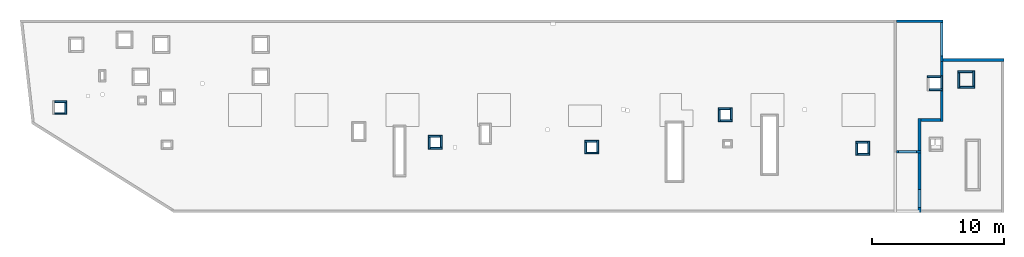
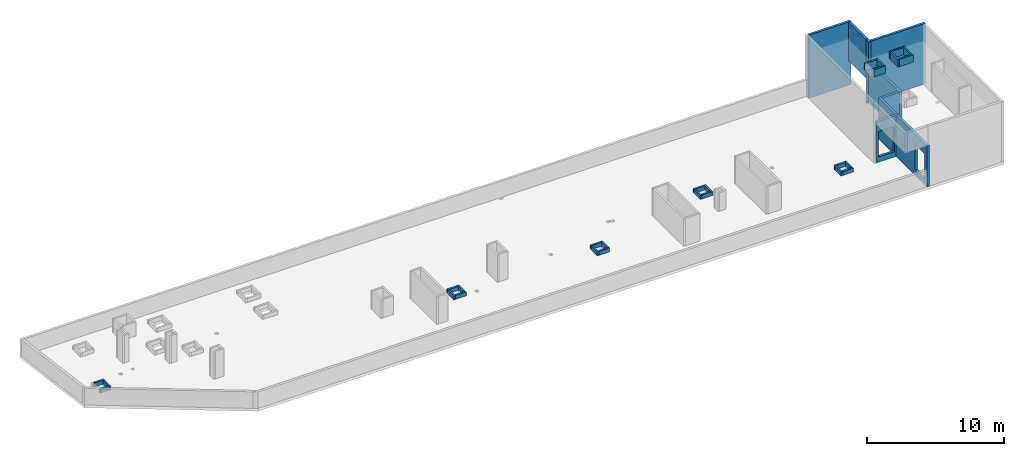
# One storey, part 3 of 3: 35 walls, 2 openings.
"""IFC4 building model written with IfcOpenShell, lengths in millimetres."""

from ifc_helpers import new_model, entity, si_unit, converted_unit, derived_unit, direction, frame, origin, place, context, subcontext, project, spatial, indexed_curve, outline, extrude, polygons, material, type_object, element, save


model = new_model("IFC4")

# Units and contexts
model_context = context("Model", 3, precision=0.01, world=origin(), true_north=direction((6.12303176911189e-17, 1.0)))
plan_context = context("Plan", 3, precision=0.01, world=origin(), true_north=direction((6.12303176911189e-17, 1.0)))
body_context = subcontext(model_context, "Body", "Model", "MODEL_VIEW")
ifc_project = project(units=[si_unit("LENGTHUNIT", "METRE", prefix="MILLI"), si_unit("AREAUNIT", "SQUARE_METRE"), si_unit("VOLUMEUNIT", "CUBIC_METRE"), converted_unit("PLANEANGLEUNIT", "DEGREE", entity("IfcRatioMeasure", 0.0174532925199433), si_unit("PLANEANGLEUNIT", "RADIAN"), dimensions=[0, 0, 0, 0, 0, 0, 0]), si_unit("MASSUNIT", "GRAM", prefix="KILO"), derived_unit("MASSDENSITYUNIT", [(si_unit("MASSUNIT", "GRAM", prefix="KILO"), 1), (si_unit("LENGTHUNIT", "METRE"), -3)]), derived_unit("MOMENTOFINERTIAUNIT", [(si_unit("LENGTHUNIT", "METRE"), 4)]), si_unit("TIMEUNIT", "SECOND"), si_unit("FREQUENCYUNIT", "HERTZ"), si_unit("THERMODYNAMICTEMPERATUREUNIT", "DEGREE_CELSIUS"), derived_unit("THERMALTRANSMITTANCEUNIT", [(si_unit("MASSUNIT", "GRAM", prefix="KILO"), 1), (si_unit("THERMODYNAMICTEMPERATUREUNIT", "KELVIN"), -1), (si_unit("TIMEUNIT", "SECOND"), -3)]), derived_unit("VOLUMETRICFLOWRATEUNIT", [(si_unit("LENGTHUNIT", "METRE"), 3), (si_unit("TIMEUNIT", "SECOND"), -1)]), derived_unit("MASSFLOWRATEUNIT", [(si_unit("MASSUNIT", "GRAM", prefix="KILO"), 1), (si_unit("TIMEUNIT", "SECOND"), -1)]), derived_unit("ROTATIONALFREQUENCYUNIT", [(si_unit("TIMEUNIT", "SECOND"), -1)]), si_unit("ELECTRICCURRENTUNIT", "AMPERE"), si_unit("ELECTRICVOLTAGEUNIT", "VOLT"), si_unit("POWERUNIT", "WATT"), si_unit("FORCEUNIT", "NEWTON", prefix="KILO"), si_unit("ILLUMINANCEUNIT", "LUX"), si_unit("LUMINOUSFLUXUNIT", "LUMEN"), si_unit("LUMINOUSINTENSITYUNIT", "CANDELA"), derived_unit("USERDEFINED", [(si_unit("MASSUNIT", "GRAM", prefix="KILO"), -1), (si_unit("LENGTHUNIT", "METRE"), -2), (si_unit("TIMEUNIT", "SECOND"), 3), (si_unit("LUMINOUSFLUXUNIT", "LUMEN"), 1)]), derived_unit("LINEARVELOCITYUNIT", [(si_unit("LENGTHUNIT", "METRE"), 1), (si_unit("TIMEUNIT", "SECOND"), -1)]), si_unit("PRESSUREUNIT", "PASCAL"), derived_unit("USERDEFINED", [(si_unit("LENGTHUNIT", "METRE"), -2), (si_unit("MASSUNIT", "GRAM", prefix="KILO"), 1), (si_unit("TIMEUNIT", "SECOND"), -2)]), derived_unit("LINEARFORCEUNIT", [(si_unit("MASSUNIT", "GRAM", prefix="KILO"), 1), (si_unit("LENGTHUNIT", "METRE"), 1), (si_unit("TIMEUNIT", "SECOND"), -2), (si_unit("LENGTHUNIT", "METRE"), -1)]), derived_unit("PLANARFORCEUNIT", [(si_unit("MASSUNIT", "GRAM", prefix="KILO"), 1), (si_unit("LENGTHUNIT", "METRE"), 1), (si_unit("TIMEUNIT", "SECOND"), -2), (si_unit("LENGTHUNIT", "METRE"), -2)])], contexts=[model_context, plan_context])

# Site, building, storey
site_placement = place(None, origin())
site = spatial("IfcSite", under=ifc_project, at=site_placement, CompositionType="ELEMENT")
building_placement = place(site_placement, origin())
building = spatial("IfcBuilding", under=site, at=building_placement, CompositionType="ELEMENT")
storey_placement = place(building_placement, frame((0.0, 0.0, 32250.0)))
storey = spatial("IfcBuildingStorey", under=building, at=storey_placement, CompositionType="ELEMENT", Elevation=32250.0)

# Walls
ifc_material = material()
wall_type_1 = type_object("IfcWallType", PredefinedType="STANDARD")
wall_1_placement = place(storey_placement, frame((68870.0002685547, 20299.9998657227, 1910.0), z_axis=(0.0, 0.0, 1.0), x_axis=(0.0, -1.0, 0.0)))
element("IfcWall", 1, at=wall_1_placement, inside=storey, type_object=wall_type_1, material=ifc_material, PredefinedType="NOTDEFINED", context=body_context, shape_type="SweptSolid", body=[
    extrude(outline(indexed_curve([(2520.0006393672, 100.000000000003), (-3.30646371005458e-13, 100.000000000003), (3.30646371005458e-13, -100.000000000003), (2520.0006393672, -100.000000000004), (2520.0006393672, 100.000000000003)], self_intersect=False)), origin(), (0.0, 0.0, 1.0), 3460.0),
])
wall_2_placement = place(storey_placement, frame((68970.0002685547, 17469.9992263555, 0.0)))
element("IfcWall", 2, at=wall_2_placement, inside=storey, type_object=wall_type_1, material=ifc_material, PredefinedType="NOTDEFINED", context=body_context, shape_type="SweptSolid", body=[
    extrude(outline(indexed_curve([(4599.9991821289, 99.9999999999989), (-3.29568315339594e-13, 99.9999999999989), (3.29568315339594e-13, -99.9999999999989), (4599.9991821289, -99.9999999999989), (4599.9991821289, 99.9999999999989)], self_intersect=False)), origin(), (0.0, 0.0, 1.0), 5370.0),
])
wall_3_placement = place(storey_placement, frame((65430.0002685547, 20399.9998657227, -250.0)))
element("IfcWall", 3, at=wall_3_placement, inside=storey, type_object=wall_type_1, material=ifc_material, PredefinedType="NOTDEFINED", context=body_context, shape_type="SweptSolid", body=[
    extrude(outline(indexed_curve([(3540.00000000006, 99.9999999999974), (-3.22401824874843e-13, 99.9999999999989), (3.22401824874843e-13, -99.9999999999989), (3540.00000000006, -100.000000000001), (3540.00000000006, 99.9999999999974)], self_intersect=False)), origin(), (0.0, 0.0, 1.0), 5620.0),
])

# Wall, opening
wall_4_placement = place(storey_placement, frame((65430.0002685546, 10524.999226356, 0.0)))
wall_4 = element("IfcWall", 4, at=wall_4_placement, inside=storey, type_object=wall_type_1, material=ifc_material, PredefinedType="NOTDEFINED", context=body_context, shape_type="Tessellation", body=[
    polygons([(-3.15235560919963e-12, -99.9999999999989, 0.0), (1649.99999999999, -99.9999999999989, 0.0), (1849.99999999999, -99.9999999999989, 0.0), (1849.99999999999, -99.9999999999989, 3650.0), (1649.99999999999, -99.9999999999989, 3650.0), (4.88252665971232e-11, -99.9999999999989, 3650.0), (150.000000000006, -99.9999999999989, 2729.99999999805), (1500.00000000001, -99.9999999999989, 2729.99999999805), (1500.0, -99.9999999999989, 450.000000000002), (150.000000000006, -99.9999999999989, 450.000000000002), (1849.99999999999, 100.000000000001, 0.0), (1650.00000000009, 100.000000000001, 0.0), (-3.87761424809092e-12, 100.000000000003, 0.0), (-3.87761424809091e-12, 100.000000000001, 3650.0), (1650.00000000009, 100.000000000001, 3650.0), (1849.99999999999, 100.000000000001, 3650.0), (1500.0, 100.000000000001, 2729.99999999805), (149.999999999997, 100.000000000001, 2729.99999999805), (149.999999999997, 100.000000000001, 450.000000000002), (1500.0, 100.000000000001, 450.000000000002), (-3.51498492864527e-12, 2.16573425859679e-12, 3650.0)], [[[1, 2, 3, 4, 5, 6], [7, 8, 9, 10]], [[11, 12, 13, 14, 15, 16], [17, 18, 19, 20]], [[3, 2, 1, 13, 12, 11]], [[1, 6, 21, 14, 13]], [[4, 3, 11, 16]], [[6, 5, 4, 16, 15, 14, 21]], [[17, 8, 7, 18]], [[18, 7, 10, 19]], [[19, 10, 9, 20]], [[8, 17, 20, 9]]], closed=True),
])
opening_1_placement = place(wall_4_placement, frame((-65430.0002685546, -10524.999226356, 0.0)))
element("IfcOpeningElement", 5, at=opening_1_placement, cuts=wall_4, PredefinedType="OPENING", context=body_context, shape_type="SweptSolid", body=[
    extrude(outline(indexed_curve([(-1139.99999999902, -674.999999999994), (1139.99999999902, -674.999999999994), (1139.99999999902, 675.000000000003), (-1139.99999999902, 675.000000000003), (-1139.99999999902, -674.999999999994)], self_intersect=False)), frame((66255.0002685546, 10324.999226356, 1590.0), z_axis=(0.0, 1.0, 0.0), x_axis=(0.0, 0.0, -1.0)), (0.0, 0.0, 1.0), 400.000000001943),
])

wall_5_placement = place(storey_placement, frame((67180.0002685546, 5929.99922635547, 0.0), z_axis=(0.0, 0.0, 1.0), x_axis=(0.0, 1.0, 0.0)))
wall_5 = element("IfcWall", 6, at=wall_5_placement, inside=storey, type_object=wall_type_1, material=ifc_material, PredefinedType="NOTDEFINED", context=body_context, shape_type="Tessellation", body=[
    polygons([(1.08286712929839e-12, -99.9999999999946, 0.0), (200.000000000001, -99.9999999999946, 0.0), (4495.00000000053, -99.9999999999946, 0.0), (4495.00000000053, -99.9999999999946, 3650.0), (199.999999999995, -99.9999999999946, 3650.0), (0.0, -99.9999999999946, 3650.0), (384.999999999998, -99.9999999999946, 2729.99999999805), (1735.0, -99.9999999999946, 2729.99999999805), (1735.0, -99.9999999999946, 450.000000000002), (384.999999999999, -99.9999999999946, 450.000000000002), (4495.00000000053, 100.000000000012, 0.0), (200.000000000001, 100.000000000003, 0.0), (2.16573425859679e-12, 100.000000000012, 0.0), (2.16573425859679e-12, 100.000000000003, 1470.0), (1.08286712929839e-12, 100.000000000012, 3650.0), (199.999999999995, 100.000000000012, 3650.0), (4495.00000000053, 100.000000000012, 3650.0), (1735.0, 100.000000000012, 2729.99999999805), (384.999999999999, 100.000000000012, 2729.99999999805), (384.999999999999, 100.000000000012, 450.000000000002), (1735.0, 100.000000000012, 450.000000000002), (0.0, 0.0, 3650.0)], [[[1, 2, 3, 4, 5, 6], [7, 8, 9, 10]], [[11, 12, 13, 14, 15, 16, 17], [18, 19, 20, 21]], [[3, 2, 1, 13, 12, 11]], [[4, 3, 11, 17]], [[6, 22, 15, 14, 13, 1]], [[15, 22, 6, 5, 16]], [[5, 4, 17, 16]], [[7, 19, 18, 8]], [[8, 18, 21, 9]], [[9, 21, 20, 10]], [[19, 7, 10, 20]]], closed=True),
])
opening_2_placement = place(wall_5_placement, frame((-5929.99922635547, 67180.0002685546, 0.0), z_axis=(0.0, 0.0, 1.0), x_axis=(0.0, -1.0, 0.0)))
element("IfcOpeningElement", 7, at=opening_2_placement, cuts=wall_5, PredefinedType="OPENING", context=body_context, shape_type="SweptSolid", body=[
    extrude(outline(indexed_curve([(-674.999999999999, -1139.99999999902), (675.0, -1139.99999999902), (675.0, 1139.99999999902), (-674.999999999999, 1139.99999999902), (-674.999999999999, -1139.99999999902)], self_intersect=False)), frame((67380.0002685566, 6989.99922635546, 1590.0), z_axis=(-1.0, 0.0, 0.0), x_axis=(0.0, 1.0, 0.0)), (0.0, 0.0, 1.0), 400.000000001936),
])

# Walls
wall_6_placement = place(storey_placement, frame((68870.0002685547, 17779.9992263555, -250.0), z_axis=(0.0, 0.0, 1.0), x_axis=(0.0, -1.0, 0.0)))
element("IfcWall", 8, at=wall_6_placement, inside=storey, type_object=wall_type_1, material=ifc_material, PredefinedType="NOTDEFINED", context=body_context, shape_type="Tessellation", body=[
    polygons([(409.999999999996, -99.9999999999946, 5620.0), (2.16573425859679e-12, -99.9999999999946, 5620.0), (0.0, -99.9999999999946, 2160.0), (2.16573425859679e-12, -99.9999999999946, 4.33146851719357e-12), (210.000000000006, -99.9999999999946, 4.33146851719357e-12), (210.000000000006, -99.9999999999946, 250.000000000004), (409.999999999996, -99.9999999999946, 250.000000000004), (409.999999999996, -99.9999999999946, 3900.00000000001), (2.16573425859679e-12, 100.000000000003, 5620.0), (209.999999999996, 100.000000000003, 5620.0), (409.999999999996, 100.000000000003, 5620.0), (409.999999999996, 100.000000000003, 3900.00000000001), (409.999999999996, 100.000000000003, 250.000000000004), (210.000000000006, 100.000000000003, 250.000000000004), (210.000000000006, 100.000000000003, 4.33146851719357e-12), (2.16573425859679e-12, 100.000000000003, 4.33146851719357e-12), (0.0, 100.000000000003, 2160.0)], [[[1, 2, 3, 4, 5, 6, 7, 8]], [[9, 10, 11, 12, 13, 14, 15, 16, 17]], [[4, 16, 15, 5]], [[2, 1, 11, 10, 9]], [[4, 3, 2, 9, 17, 16]], [[11, 1, 8, 7, 13, 12]], [[6, 14, 13, 7]], [[14, 6, 5, 15]]], closed=True),
])
wall_7_placement = place(storey_placement, frame((67180.0002685547, 10624.999226356, 0.0), z_axis=(0.0, 0.0, 1.0), x_axis=(0.0, 1.0, 0.0)))
element("IfcWall", 9, at=wall_7_placement, inside=storey, type_object=wall_type_1, material=ifc_material, PredefinedType="NOTDEFINED", context=body_context, shape_type="Tessellation", body=[
    polygons([(0.0, -99.9999999999859, 0.0), (2204.99999999949, -99.9999999999946, 0.0), (2404.99999999949, -99.9999999999859, 0.0), (2404.99999999949, -99.9999999999859, 3650.0), (2204.99999999949, -99.9999999999946, 3650.0), (0.0, -99.9999999999859, 3650.0), (2.16573425859679e-12, 100.000000000003, 0.0), (2.16573425859679e-12, 100.000000000003, 3650.0), (2404.99999999949, 100.000000000003, 3650.0), (2404.99999999949, 100.000000000003, 0.0)], [[[1, 2, 3, 4, 5, 6]], [[7, 8, 9, 10]], [[3, 2, 1, 7, 10]], [[4, 3, 10, 9]], [[1, 6, 8, 7]], [[6, 5, 4, 9, 8]]], closed=True),
])
wall_8_placement = place(storey_placement, frame((68870.0002685547, 17369.9992263555, 0.0), z_axis=(0.0, 0.0, 1.0), x_axis=(0.0, -1.0, 0.0)))
element("IfcWall", 10, at=wall_8_placement, inside=storey, type_object=wall_type_1, material=ifc_material, PredefinedType="NOTDEFINED", context=body_context, shape_type="Tessellation", body=[
    polygons([(0.0, -99.9999999999954, 0.0), (4339.99999999999, -99.9999999999952, 0.0), (4539.99999999999, -99.9999999999948, 0.0), (4539.99999999999, -99.9999999999948, 3650.0), (4339.99999999999, -99.9999999999952, 3650.0), (0.0, -99.9999999999954, 3650.0), (0.0, 100.000000000011, 0.0), (0.0, 100.000000000011, 3650.0), (4539.99999999999, 100.000000000003, 3650.0), (4539.99999999999, 100.000000000003, 0.0)], [[[1, 2, 3, 4, 5, 6]], [[7, 8, 9, 10]], [[3, 2, 1, 7, 10]], [[4, 3, 10, 9]], [[1, 6, 8, 7]], [[6, 5, 4, 9, 8]]], closed=True),
])
wall_9_placement = place(storey_placement, frame((68770.0002685547, 12929.9992263555, 0.0), z_axis=(0.0, 0.0, 1.0), x_axis=(-1.0, 0.0, 0.0)))
element("IfcWall", 11, at=wall_9_placement, inside=storey, type_object=wall_type_1, material=ifc_material, PredefinedType="NOTDEFINED", context=body_context, shape_type="Tessellation", body=[
    polygons([(2.74677004661093e-12, -100.000000000001, 0.0), (1489.99999999997, -100.000000000001, 0.0), (1489.99999999997, -100.000000000001, 3650.0), (2.74677004661093e-12, -100.000000000001, 3650.0), (2.17273289534979e-12, 99.9999999999989, 0.0), (2.17273289534979e-12, 99.9999999999989, 3650.0), (1489.99999999997, 99.9999999999989, 3650.0), (1489.99999999997, 99.9999999999989, 0.0)], [[[1, 2, 3, 4]], [[5, 6, 7, 8]], [[2, 1, 5, 8]], [[1, 4, 6, 5]], [[3, 2, 8, 7]], [[4, 3, 7, 6]]], closed=True),
])
wall_type_2 = type_object("IfcWallType", PredefinedType="STANDARD")
wall_10_placement = place(storey_placement, frame((1735.00026855467, 14324.9992263564, 0.0)))
element("IfcWall", 12, at=wall_10_placement, inside=storey, type_object=wall_type_2, material=ifc_material, PredefinedType="NOTDEFINED", context=body_context, shape_type="SweptSolid", body=[
    extrude(outline(indexed_curve([(900.0, 75.0000000000007), (5.41433564649185e-14, 75.0000000000003), (-5.41433564649185e-14, -75.0000000000003), (900.0, -74.9999999999998), (900.0, 75.0000000000007)], self_intersect=False)), origin(), (0.0, 0.0, 1.0), 349.999999999998),
])
wall_11_placement = place(storey_placement, frame((2560.00026855467, 14249.9992263564, 0.0), z_axis=(0.0, 0.0, 1.0), x_axis=(0.0, -1.0, 0.0)))
element("IfcWall", 13, at=wall_11_placement, inside=storey, type_object=wall_type_2, material=ifc_material, PredefinedType="NOTDEFINED", context=body_context, shape_type="SweptSolid", body=[
    extrude(outline(indexed_curve([(900.000000000001, 75.0000000000005), (-1.0828671292984e-13, 75.0000000000003), (1.0828671292984e-13, -75.0000000000003), (900.000000000001, -75.0000000000001), (900.000000000001, 75.0000000000005)], self_intersect=False)), origin(), (0.0, 0.0, 1.0), 349.999999999998),
])
wall_12_placement = place(storey_placement, frame((2485.00026855467, 13424.9992263564, 0.0), z_axis=(0.0, 0.0, 1.0), x_axis=(-1.0, 0.0, 0.0)))
element("IfcWall", 14, at=wall_12_placement, inside=storey, type_object=wall_type_2, material=ifc_material, PredefinedType="NOTDEFINED", context=body_context, shape_type="SweptSolid", body=[
    extrude(outline(indexed_curve([(750.0, 75.0000000000003), (0.0, 75.0000000000003), (0.0, -75.0000000000003), (750.0, -75.0000000000003), (750.0, 75.0000000000003)], self_intersect=False)), origin(), (0.0, 0.0, 1.0), 349.999999999998),
])
wall_13_placement = place(storey_placement, frame((30010.0002685547, 11709.9992263562, 0.0)))
element("IfcWall", 15, at=wall_13_placement, inside=storey, type_object=wall_type_2, material=ifc_material, PredefinedType="NOTDEFINED", context=body_context, shape_type="SweptSolid", body=[
    extrude(outline(indexed_curve([(900.000000000003, 75.0000000000003), (0.0, 75.0000000000003), (0.0, -75.0000000000003), (900.000000000003, -75.0000000000003), (900.000000000003, 75.0000000000003)], self_intersect=False)), origin(), (0.0, 0.0, 1.0), 349.999999999998),
])
for number, where, z_axis, x_axis in (
    (16, (30085.0002685547, 10734.9992263562, 0.0), (0.0, 0.0, 1.0), (0.0, 1.0, 0.0)),
    (17, (31060.0002685547, 10809.9992263562, 0.0), (0.0, 0.0, 1.0), (-1.0, 0.0, 0.0)),
    (18, (30985.0002685547, 11784.9992263562, 0.0), (0.0, 0.0, 1.0), (0.0, -1.0, 0.0)),
):
    element("IfcWall", number, at=place(storey_placement, frame(where, z_axis=z_axis, x_axis=x_axis)), inside=storey, type_object=wall_type_2, material=ifc_material, PredefinedType="NOTDEFINED", context=body_context, shape_type="SweptSolid", body=[
        extrude(outline(indexed_curve([(900.000000000003, 75.0000000000003), (0.0, 75.0000000000003), (0.0, -75.0000000000003), (900.000000000003, -75.0000000000003), (900.000000000003, 75.0000000000003)], self_intersect=False)), origin(), (0.0, 0.0, 1.0), 349.999999999998),
    ])
wall_14_placement = place(storey_placement, frame((41860.0002685547, 11334.9992263561, 0.0)))
element("IfcWall", 19, at=wall_14_placement, inside=storey, type_object=wall_type_2, material=ifc_material, PredefinedType="NOTDEFINED", context=body_context, shape_type="SweptSolid", body=[
    extrude(outline(indexed_curve([(900.000000000012, 75.0000000000003), (0.0, 75.0000000000003), (0.0, -75.0000000000003), (900.000000000012, -75.0000000000003), (900.000000000012, 75.0000000000003)], self_intersect=False)), origin(), (0.0, 0.0, 1.0), 349.999999999998),
])
wall_15_placement = place(storey_placement, frame((41935.0002685547, 10359.9992263561, 0.0), z_axis=(0.0, 0.0, 1.0), x_axis=(0.0, 1.0, 0.0)))
element("IfcWall", 20, at=wall_15_placement, inside=storey, type_object=wall_type_2, material=ifc_material, PredefinedType="NOTDEFINED", context=body_context, shape_type="SweptSolid", body=[
    extrude(outline(indexed_curve([(899.999999999995, 75.0000000000003), (0.0, 75.0000000000003), (0.0, -75.0000000000003), (899.999999999995, -75.0000000000003), (899.999999999995, 75.0000000000003)], self_intersect=False)), origin(), (0.0, 0.0, 1.0), 349.999999999998),
])
wall_16_placement = place(storey_placement, frame((42910.0002685547, 10434.9992263561, 0.0), z_axis=(0.0, 0.0, 1.0), x_axis=(-1.0, 0.0, 0.0)))
element("IfcWall", 21, at=wall_16_placement, inside=storey, type_object=wall_type_2, material=ifc_material, PredefinedType="NOTDEFINED", context=body_context, shape_type="SweptSolid", body=[
    extrude(outline(indexed_curve([(900.000000000012, 75.0000000000003), (0.0, 75.0000000000003), (0.0, -75.0000000000003), (900.000000000012, -75.0000000000003), (900.000000000012, 75.0000000000003)], self_intersect=False)), origin(), (0.0, 0.0, 1.0), 349.999999999998),
])
wall_17_placement = place(storey_placement, frame((42835.0002685547, 11409.9992263561, 0.0), z_axis=(0.0, 0.0, 1.0), x_axis=(0.0, -1.0, 0.0)))
element("IfcWall", 22, at=wall_17_placement, inside=storey, type_object=wall_type_2, material=ifc_material, PredefinedType="NOTDEFINED", context=body_context, shape_type="SweptSolid", body=[
    extrude(outline(indexed_curve([(899.999999999995, 75.0000000000003), (0.0, 75.0000000000003), (0.0, -75.0000000000003), (899.999999999995, -75.0000000000003), (899.999999999995, 75.0000000000003)], self_intersect=False)), origin(), (0.0, 0.0, 1.0), 349.999999999998),
])
wall_18_placement = place(storey_placement, frame((51960.0002685547, 13774.9992263561, 0.0)))
element("IfcWall", 23, at=wall_18_placement, inside=storey, type_object=wall_type_2, material=ifc_material, PredefinedType="NOTDEFINED", context=body_context, shape_type="SweptSolid", body=[
    extrude(outline(indexed_curve([(900.000000000012, 75.0000000000003), (0.0, 75.0000000000003), (0.0, -75.0000000000003), (900.000000000012, -75.0000000000003), (900.000000000012, 75.0000000000003)], self_intersect=False)), origin(), (0.0, 0.0, 1.0), 349.999999999998),
])
wall_19_placement = place(storey_placement, frame((52035.0002685547, 12799.9992263561, 0.0), z_axis=(0.0, 0.0, 1.0), x_axis=(0.0, 1.0, 0.0)))
element("IfcWall", 24, at=wall_19_placement, inside=storey, type_object=wall_type_2, material=ifc_material, PredefinedType="NOTDEFINED", context=body_context, shape_type="SweptSolid", body=[
    extrude(outline(indexed_curve([(900.000000000008, 75.0000000000003), (0.0, 75.0000000000003), (0.0, -75.0000000000003), (900.000000000008, -75.0000000000003), (900.000000000008, 75.0000000000003)], self_intersect=False)), origin(), (0.0, 0.0, 1.0), 349.999999999998),
])
wall_20_placement = place(storey_placement, frame((53010.0002685547, 12874.9992263561, 0.0), z_axis=(0.0, 0.0, 1.0), x_axis=(-1.0, 0.0, 0.0)))
element("IfcWall", 25, at=wall_20_placement, inside=storey, type_object=wall_type_2, material=ifc_material, PredefinedType="NOTDEFINED", context=body_context, shape_type="SweptSolid", body=[
    extrude(outline(indexed_curve([(900.000000000012, 75.0000000000003), (0.0, 75.0000000000003), (0.0, -75.0000000000003), (900.000000000012, -75.0000000000003), (900.000000000012, 75.0000000000003)], self_intersect=False)), origin(), (0.0, 0.0, 1.0), 349.999999999998),
])
wall_21_placement = place(storey_placement, frame((52935.0002685547, 13849.9992263561, 0.0), z_axis=(0.0, 0.0, 1.0), x_axis=(0.0, -1.0, 0.0)))
element("IfcWall", 26, at=wall_21_placement, inside=storey, type_object=wall_type_2, material=ifc_material, PredefinedType="NOTDEFINED", context=body_context, shape_type="SweptSolid", body=[
    extrude(outline(indexed_curve([(900.000000000008, 75.0000000000003), (0.0, 75.0000000000003), (0.0, -75.0000000000003), (900.000000000008, -75.0000000000003), (900.000000000008, 75.0000000000003)], self_intersect=False)), origin(), (0.0, 0.0, 1.0), 349.999999999998),
])
wall_22_placement = place(storey_placement, frame((62345.0002685547, 11234.999226356, 0.0)))
element("IfcWall", 27, at=wall_22_placement, inside=storey, type_object=wall_type_2, material=ifc_material, PredefinedType="NOTDEFINED", context=body_context, shape_type="SweptSolid", body=[
    extrude(outline(indexed_curve([(899.999999999995, 75.0000000000003), (0.0, 75.0000000000003), (0.0, -75.0000000000003), (899.999999999995, -75.0000000000003), (899.999999999995, 75.0000000000003)], self_intersect=False)), origin(), (0.0, 0.0, 1.0), 349.999999999998),
])
wall_23_placement = place(storey_placement, frame((62420.0002685547, 10259.999226356, 0.0), z_axis=(0.0, 0.0, 1.0), x_axis=(0.0, 1.0, 0.0)))
element("IfcWall", 28, at=wall_23_placement, inside=storey, type_object=wall_type_2, material=ifc_material, PredefinedType="NOTDEFINED", context=body_context, shape_type="SweptSolid", body=[
    extrude(outline(indexed_curve([(900.00000000001, 75.0000000000003), (0.0, 75.0000000000003), (0.0, -75.0000000000003), (900.00000000001, -75.0000000000003), (900.00000000001, 75.0000000000003)], self_intersect=False)), origin(), (0.0, 0.0, 1.0), 349.999999999998),
])
wall_24_placement = place(storey_placement, frame((63395.0002685547, 10334.999226356, 0.0), z_axis=(0.0, 0.0, 1.0), x_axis=(-1.0, 0.0, 0.0)))
element("IfcWall", 29, at=wall_24_placement, inside=storey, type_object=wall_type_2, material=ifc_material, PredefinedType="NOTDEFINED", context=body_context, shape_type="SweptSolid", body=[
    extrude(outline(indexed_curve([(899.999999999995, 75.0000000000003), (0.0, 75.0000000000003), (0.0, -75.0000000000003), (899.999999999995, -75.0000000000003), (899.999999999995, 75.0000000000003)], self_intersect=False)), origin(), (0.0, 0.0, 1.0), 349.999999999998),
])
wall_25_placement = place(storey_placement, frame((63320.0002685547, 11309.999226356, 0.0), z_axis=(0.0, 0.0, 1.0), x_axis=(0.0, -1.0, 0.0)))
element("IfcWall", 30, at=wall_25_placement, inside=storey, type_object=wall_type_2, material=ifc_material, PredefinedType="NOTDEFINED", context=body_context, shape_type="SweptSolid", body=[
    extrude(outline(indexed_curve([(900.00000000001, 75.0000000000003), (0.0, 75.0000000000003), (0.0, -75.0000000000003), (900.00000000001, -75.0000000000003), (900.00000000001, 75.0000000000003)], self_intersect=False)), origin(), (0.0, 0.0, 1.0), 349.999999999998),
])
wall_26_placement = place(storey_placement, frame((67770.0002685547, 16214.999226356, 3900.0)))
element("IfcWall", 31, at=wall_26_placement, inside=storey, type_object=wall_type_2, material=ifc_material, PredefinedType="NOTDEFINED", context=body_context, shape_type="SweptSolid", body=[
    extrude(outline(indexed_curve([(999.999999999998, 75.0000000000003), (0.0, 75.0000000000003), (0.0, -75.0000000000003), (999.999999999998, -75.0000000000003), (999.999999999998, 75.0000000000003)], self_intersect=False)), origin(), (0.0, 0.0, 1.0), 650.0),
])
wall_27_placement = place(storey_placement, frame((68920.0002685547, 15214.999226356, 3900.0), z_axis=(0.0, 0.0, 1.0), x_axis=(-1.0, 0.0, 0.0)))
element("IfcWall", 32, at=wall_27_placement, inside=storey, type_object=wall_type_2, material=ifc_material, PredefinedType="NOTDEFINED", context=body_context, shape_type="SweptSolid", body=[
    extrude(outline(indexed_curve([(999.999999999998, 75.0000000000003), (0.0, 75.0000000000003), (0.0, -75.0000000000003), (999.999999999998, -75.0000000000003), (999.999999999998, 75.0000000000003)], self_intersect=False)), origin(), (0.0, 0.0, 1.0), 650.0),
])
wall_28_placement = place(storey_placement, frame((68845.0002685547, 16289.999226356, 3900.0), z_axis=(0.0, 0.0, 1.0), x_axis=(0.0, -1.0, 0.0)))
element("IfcWall", 33, at=wall_28_placement, inside=storey, type_object=wall_type_2, material=ifc_material, PredefinedType="NOTDEFINED", context=body_context, shape_type="SweptSolid", body=[
    extrude(outline(indexed_curve([(1000.0, 75.0000000000003), (0.0, 75.0000000000003), (0.0, -75.0000000000003), (1000.0, -75.0000000000003), (1000.0, 75.0000000000003)], self_intersect=False)), origin(), (0.0, 0.0, 1.0), 650.0),
])
wall_29_placement = place(storey_placement, frame((70070.0002685547, 16574.999226356, 3900.0)))
element("IfcWall", 34, at=wall_29_placement, inside=storey, type_object=wall_type_2, material=ifc_material, PredefinedType="NOTDEFINED", context=body_context, shape_type="SweptSolid", body=[
    extrude(outline(indexed_curve([(1150.0, 75.0000000000003), (0.0, 75.0000000000003), (0.0, -75.0000000000003), (1150.0, -75.0000000000003), (1150.0, 75.0000000000003)], self_intersect=False)), origin(), (0.0, 0.0, 1.0), 650.0),
])
wall_30_placement = place(storey_placement, frame((70145.0002685547, 15349.999226356, 3900.0), z_axis=(0.0, 0.0, 1.0), x_axis=(0.0, 1.0, 0.0)))
element("IfcWall", 35, at=wall_30_placement, inside=storey, type_object=wall_type_2, material=ifc_material, PredefinedType="NOTDEFINED", context=body_context, shape_type="SweptSolid", body=[
    extrude(outline(indexed_curve([(1150.0, 75.0000000000003), (0.0, 75.0000000000003), (0.0, -75.0000000000003), (1150.0, -75.0000000000003), (1150.0, 75.0000000000003)], self_intersect=False)), origin(), (0.0, 0.0, 1.0), 650.0),
])
wall_31_placement = place(storey_placement, frame((71370.0002685547, 15424.999226356, 3900.0), z_axis=(0.0, 0.0, 1.0), x_axis=(-1.0, 0.0, 0.0)))
element("IfcWall", 36, at=wall_31_placement, inside=storey, type_object=wall_type_2, material=ifc_material, PredefinedType="NOTDEFINED", context=body_context, shape_type="SweptSolid", body=[
    extrude(outline(indexed_curve([(1150.0, 74.9999999999999), (-1.16021478139114e-13, 75.0000000000003), (1.16021478139114e-13, -75.0000000000003), (1150.0, -75.0000000000007), (1150.0, 74.9999999999999)], self_intersect=False)), origin(), (0.0, 0.0, 1.0), 650.0),
])
wall_32_placement = place(storey_placement, frame((71295.0002685547, 16649.999226356, 3900.0), z_axis=(0.0, 0.0, 1.0), x_axis=(0.0, -1.0, 0.0)))
element("IfcWall", 37, at=wall_32_placement, inside=storey, type_object=wall_type_2, material=ifc_material, PredefinedType="NOTDEFINED", context=body_context, shape_type="SweptSolid", body=[
    extrude(outline(indexed_curve([(1150.0, 75.0000000000003), (0.0, 75.0000000000003), (0.0, -75.0000000000003), (1150.0, -75.0000000000003), (1150.0, 75.0000000000003)], self_intersect=False)), origin(), (0.0, 0.0, 1.0), 650.0),
])

save(model, "model.ifc")
